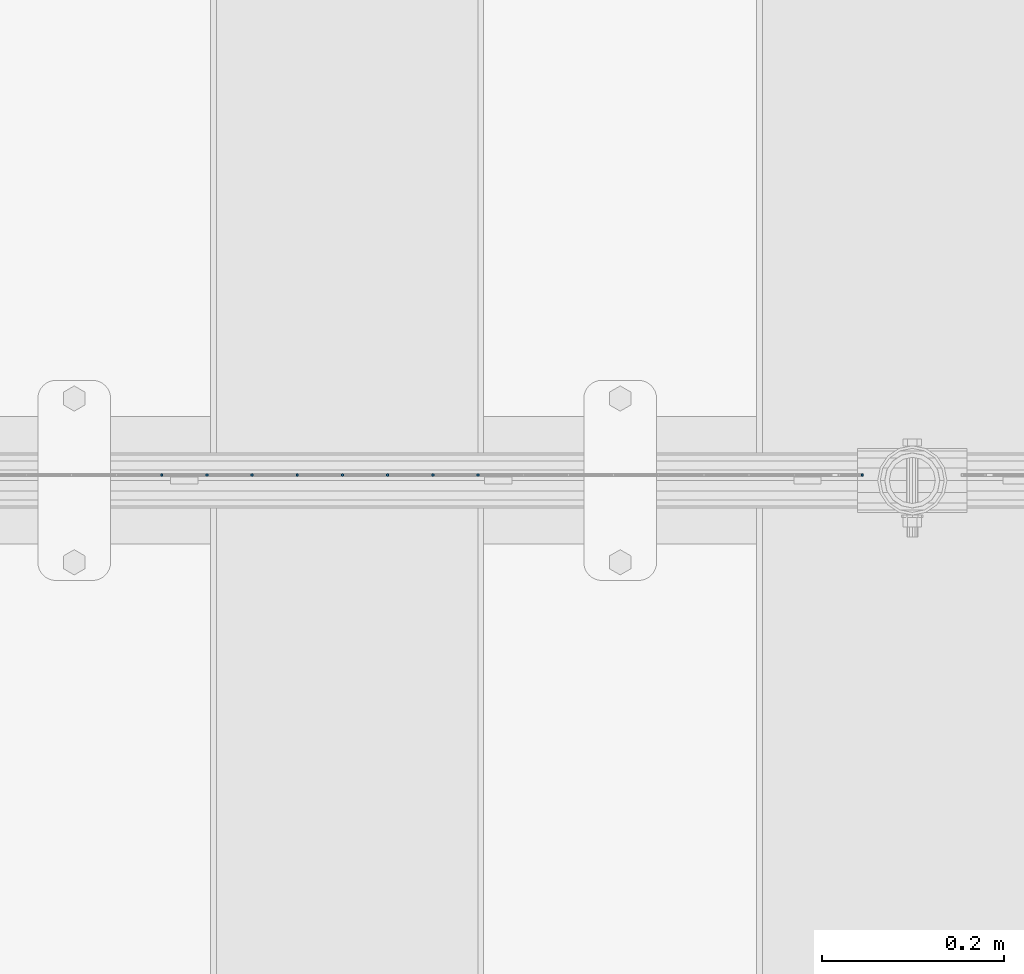
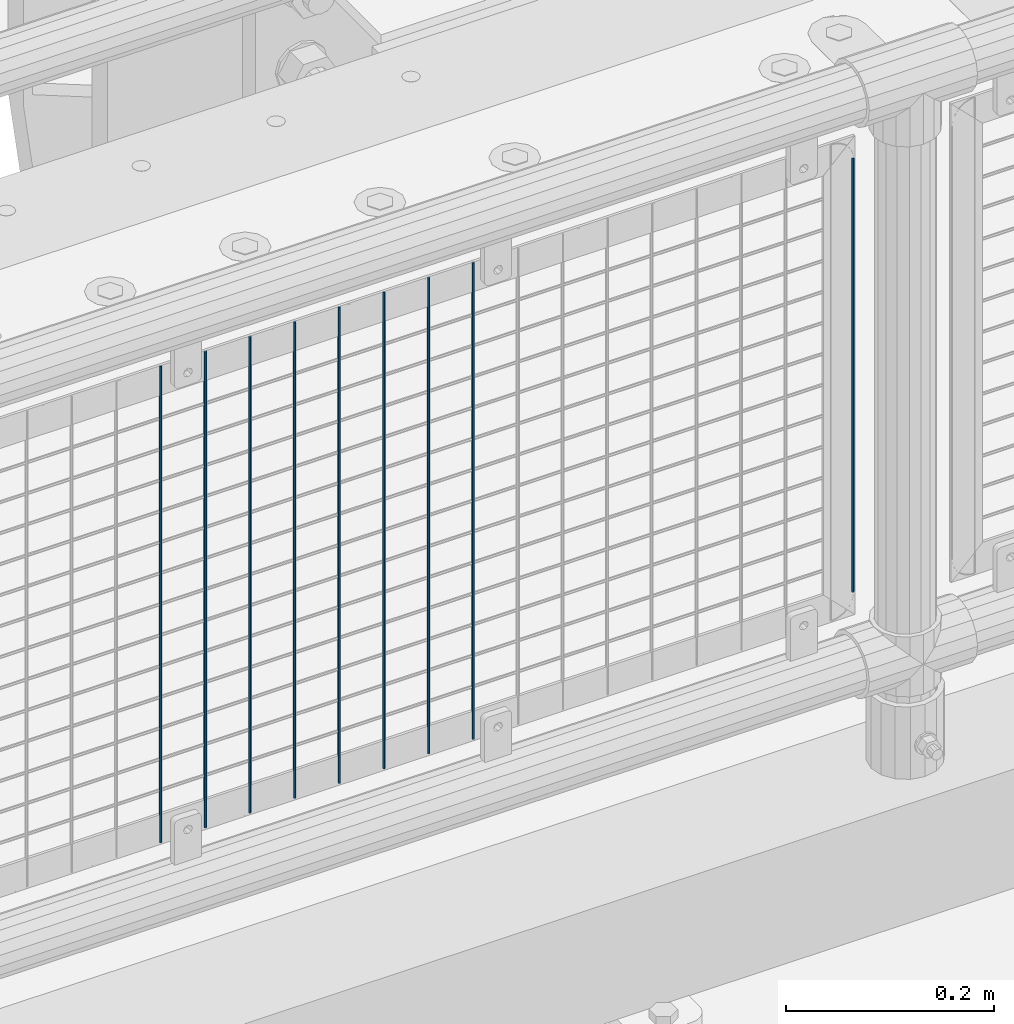
# One storey, part 78 of 208: 9 columns.
"""IFC2X3 building model written with IfcOpenShell, lengths in millimetres."""

import ifcopenshell
import ifcopenshell.guid

model = None  # the IFC model being written
_history = None  # IfcOwnerHistory: only IFC2X3 demands one
_inside = {}  # id of a spatial element -> (the spatial element, [elements in it])
_under = {}  # id of a project, library or spatial element -> (it, [spatial elements below it])
_declared = {}  # id of a project -> (the project, [libraries it declares])
_typed = {}  # id of a type object -> (the type object, [elements of that type])
_made_of = {}  # id of a material, layer set ... -> (it, [elements and type objects made of it])


def new_model(schema):
    """Start an empty IFC model of exactly this schema.

    Asked for "IFC4X3", IfcOpenShell would pick the latest addendum, in which some entities
    have other attributes; the version numbers below select the first issue.
    IFC2X3 requires an IfcOwnerHistory on every rooted entity: one is made here for all.
    """
    global model, _history
    if schema == "IFC4X3":
        model = ifcopenshell.file(schema_version=(4, 3, 0, 0))
    else:
        model = ifcopenshell.file(schema=schema)
    _inside.clear()
    _under.clear()
    _declared.clear()
    _typed.clear()
    _made_of.clear()
    _history = None
    if model.schema == "IFC2X3":
        org = make("IfcOrganization", Name="unknown")
        user = make(
            "IfcPersonAndOrganization",
            ThePerson=make("IfcPerson", FamilyName="unknown"),
            TheOrganization=org,
        )
        app = make(
            "IfcApplication",
            ApplicationDeveloper=org,
            Version="unknown",
            ApplicationFullName="unknown",
            ApplicationIdentifier="unknown",
        )
        _history = make(
            "IfcOwnerHistory",
            OwningUser=user,
            OwningApplication=app,
            ChangeAction="ADDED",
            CreationDate=0,
        )
    return model


def make(cls, **values):
    """One entity of the class cls with the attributes given. An attribute that is None is left unset."""
    return model.create_entity(
        cls, **{name: value for name, value in values.items() if value is not None}
    )


def rooted(cls, **values):
    """An entity with a GlobalId (a new one), such as an element, a storey or a relation."""
    return make(cls, GlobalId=ifcopenshell.guid.new(), OwnerHistory=_history, **values)


def si_unit(unit_type, name, prefix=None):
    """IfcSIUnit, for example si_unit("LENGTHUNIT", "METRE", prefix="MILLI")."""
    return make("IfcSIUnit", UnitType=unit_type, Prefix=prefix, Name=name)


def assignment(units):
    """IfcUnitAssignment: the units of a project."""
    return None if units is None else make("IfcUnitAssignment", Units=units)


def point(xyz):
    """IfcCartesianPoint."""
    return None if xyz is None else make("IfcCartesianPoint", Coordinates=xyz)


def direction(xyz):
    """IfcDirection."""
    return None if xyz is None else make("IfcDirection", DirectionRatios=xyz)


def frame(location, z_axis=None, x_axis=None):
    """IfcAxis2Placement3D, a coordinate frame: its origin and axes. An axis left out is left unset."""
    return make(
        "IfcAxis2Placement3D",
        Location=point(location),
        Axis=direction(z_axis),
        RefDirection=direction(x_axis),
    )


def origin_with_axes():
    """The frame at (0, 0, 0) with the z axis (0, 0, 1) and the x axis (1, 0, 0) written out."""
    return frame((0.0, 0.0, 0.0), z_axis=(0.0, 0.0, 1.0), x_axis=(1.0, 0.0, 0.0))


def place(relative_to, where):
    """IfcLocalPlacement: puts the frame where relative to a parent placement (None: the world)."""
    return make(
        "IfcLocalPlacement", PlacementRelTo=relative_to, RelativePlacement=where
    )


def context(
    kind, dimensions, precision=None, world=None, true_north=None, identifier=None
):
    """IfcGeometricRepresentationContext, for example the 3D "Model" context."""
    return make(
        "IfcGeometricRepresentationContext",
        ContextIdentifier=identifier,
        ContextType=kind,
        CoordinateSpaceDimension=dimensions,
        Precision=precision,
        WorldCoordinateSystem=world,
        TrueNorth=true_north,
    )


def subcontext(parent, identifier, kind, view, scale=None):
    """IfcGeometricRepresentationSubContext, for example "Body" below "Model"."""
    return make(
        "IfcGeometricRepresentationSubContext",
        ContextIdentifier=identifier,
        ContextType=kind,
        ParentContext=parent,
        TargetScale=scale,
        TargetView=view,
    )


def project(units=None, contexts=None):
    """IfcProject with its units and contexts."""
    return rooted(
        "IfcProject",
        Name="project",
        RepresentationContexts=contexts,
        UnitsInContext=assignment(units),
    )


def spatial(cls, under=None, at=None, **own):
    """A site, building, storey or space (cls), placed at a placement, below another one or the project."""
    s = rooted(cls, ObjectPlacement=at, **own)
    if under is not None:
        _under.setdefault(under.id(), (under, []))[1].append(s)
    return s


def faces_of(points, faces, orient=None, outer=None):
    """IfcFace entities. A face is a list of loops; a loop is a list of indices into points, from 0.

    orient and outer hold one flag for each loop. By default every Orientation is true, the
    first loop of a face is its IfcFaceOuterBound and the others are IfcFaceBound.
    """
    made = []
    for i, loops in enumerate(faces):
        bounds = []
        for j, loop in enumerate(loops):
            is_outer = j == 0 if outer is None else outer[i][j]
            bounds.append(
                make(
                    "IfcFaceOuterBound" if is_outer else "IfcFaceBound",
                    Bound=make("IfcPolyLoop", Polygon=[points[k] for k in loop]),
                    Orientation=True if orient is None else orient[i][j],
                )
            )
        made.append(make("IfcFace", Bounds=bounds))
    return made


def faceted_brep(points, faces, orient=None, outer=None, voids=None):
    """IfcFacetedBrep: a solid bounded by flat faces; with voids (closed shells), ...WithVoids."""
    shared = [point(p) for p in points]
    hull = make("IfcClosedShell", CfsFaces=faces_of(shared, faces, orient, outer))
    if voids is None:
        return make("IfcFacetedBrep", Outer=hull)
    return make(
        "IfcFacetedBrepWithVoids",
        Outer=hull,
        Voids=[
            make(cls, CfsFaces=faces_of(shared, fs, o, b)) for cls, fs, o, b in voids
        ],
    )


def shape(context_of_items, identifier, shape_type, items):
    """IfcShapeRepresentation: the items that make up one representation, for example the "Body"."""
    return make(
        "IfcShapeRepresentation",
        ContextOfItems=context_of_items,
        RepresentationIdentifier=identifier,
        RepresentationType=shape_type,
        Items=items,
    )


def material(Name=None, Category=None):
    """IfcMaterial."""
    return make("IfcMaterial", Name=Name, Category=Category)


def made_of(thing, what):
    """Note that an element or type object is made of a material, layer set ...; save() writes the relation."""
    if what is not None:
        _made_of.setdefault(what.id(), (what, []))[1].append(thing)
    return thing


def type_object(cls, material=None, **own):
    """A type object (cls), such as IfcWallType, which elements share."""
    return made_of(rooted(cls, **own), material)


def element(
    cls,
    number,
    at=None,
    inside=None,
    cuts=None,
    type_object=None,
    material=None,
    context=None,
    identifier="Body",
    shape_type=None,
    held_by="IfcProductDefinitionShape",
    body=None,
    shapes=None,
    **own,
):
    """One element of the class cls, such as IfcWall. Its Tag is "e" and its number.

    at: its placement. inside: the storey or other place that contains it. cuts: it is an
    opening in that element (IfcRelVoidsElement). A single representation is given by context,
    identifier, shape_type and body (its items); several are given by shapes. held_by: the class
    of the entity that holds the representations. save() writes the other relations.
    """
    e = rooted(cls, Tag="e%d" % number, ObjectPlacement=at, **own)
    if body is not None:
        shapes = [shape(context, identifier, shape_type, body)]
    if shapes is not None:
        e.Representation = make(held_by, Representations=shapes)
    if inside is not None:
        _inside.setdefault(inside.id(), (inside, []))[1].append(e)
    if cuts is not None:
        rooted(
            "IfcRelVoidsElement", RelatingBuildingElement=cuts, RelatedOpeningElement=e
        )
    if type_object is not None:
        _typed.setdefault(type_object.id(), (type_object, []))[1].append(e)
    return made_of(e, material)


def aggregate(whole, parts):
    """IfcRelAggregates: a whole, such as a stair, and the parts it consists of."""
    return rooted("IfcRelAggregates", RelatingObject=whole, RelatedObjects=parts)


def save(model, path):
    """Write the relations noted so far, then the file.

    IfcRelAggregates (storeys below a building ...), IfcRelContainedInSpatialStructure (elements
    in a storey), IfcRelDefinesByType, IfcRelAssociatesMaterial and IfcRelDeclares: one each for
    every whole, place, type object, material and project.
    """
    for whole, parts in _under.values():
        aggregate(whole, parts)
    for where, things in _inside.values():
        rooted(
            "IfcRelContainedInSpatialStructure",
            RelatedElements=things,
            RelatingStructure=where,
        )
    for kind, things in _typed.values():
        rooted("IfcRelDefinesByType", RelatedObjects=things, RelatingType=kind)
    for what, things in _made_of.values():
        rooted("IfcRelAssociatesMaterial", RelatedObjects=things, RelatingMaterial=what)
    for by, libraries in _declared.values():
        rooted("IfcRelDeclares", RelatingContext=by, RelatedDefinitions=libraries)
    model.write(path)


model = new_model("IFC2X3")

# Units and contexts
model_context = context("Model", 3, precision=1e-05, world=origin_with_axes())
body_context = subcontext(model_context, "Body", "Model", "MODEL_VIEW")
ifc_project = project(units=[si_unit("LENGTHUNIT", "METRE", prefix="MILLI"), si_unit("AREAUNIT", "SQUARE_METRE"), si_unit("VOLUMEUNIT", "CUBIC_METRE"), si_unit("MASSUNIT", "GRAM", prefix="KILO"), si_unit("TIMEUNIT", "SECOND"), si_unit("PLANEANGLEUNIT", "RADIAN"), si_unit("SOLIDANGLEUNIT", "STERADIAN"), si_unit("THERMODYNAMICTEMPERATUREUNIT", "DEGREE_CELSIUS"), si_unit("LUMINOUSINTENSITYUNIT", "LUMEN")], contexts=[model_context])

# Site, building, storey
site_placement = place(None, origin_with_axes())
site = spatial("IfcSite", under=ifc_project, at=site_placement, CompositionType="ELEMENT")
building_placement = place(site_placement, origin_with_axes())
building = spatial("IfcBuilding", under=site, at=building_placement, Name="Standard", CompositionType="ELEMENT")
storey_placement = place(building_placement, origin_with_axes())
storey = spatial("IfcBuildingStorey", under=building, at=storey_placement, Name="Undefined", CompositionType="ELEMENT", Elevation=0.0)

# Columns
ifc_material = material(Name="Misc_Undefined")
column_type = type_object("IfcColumnType", Name="D3", PredefinedType="NOTDEFINED")
for number, where, z_axis, x_axis in (
    (1, (-31106.245, 4670.50000000001, 353.020000000004), (-1.0, 0.0, 0.0), (0.0, 0.0, 1.0)),
    (2, (-31155.9, 4670.50000000001, 353.020000000004), (-1.0, 0.0, 0.0), (0.0, 0.0, 1.0)),
    (3, (-31205.555, 4670.50000000001, 353.020000000004), (-1.0, 0.0, 0.0), (0.0, 0.0, 1.0)),
    (4, (-31255.21, 4670.50000000001, 353.020000000004), (-1.0, 0.0, 0.0), (0.0, 0.0, 1.0)),
    (5, (-31304.865, 4670.50000000001, 353.020000000004), (-1.0, 0.0, 0.0), (0.0, 0.0, 1.0)),
    (6, (-31354.52, 4670.50000000001, 353.020000000004), (-1.0, 0.0, 0.0), (0.0, 0.0, 1.0)),
    (7, (-31404.175, 4670.50000000001, 353.020000000004), (-1.0, 0.0, 0.0), (0.0, 0.0, 1.0)),
    (8, (-31453.83, 4670.50000000001, 353.020000000004), (-1.0, 0.0, 0.0), (0.0, 0.0, 1.0)),
):
    element("IfcColumn", number, at=place(storey_placement, frame(where, z_axis=z_axis, x_axis=x_axis)), inside=storey, type_object=column_type, material=ifc_material, ObjectType="D3", context=body_context, shape_type="Brep", body=[
        faceted_brep([(0.0, -1.49999999999909, 3.63797880709171e-12), (-7.27595761418343e-12, -0.749999999999091, -1.29903810567669), (560.0, -0.75, -1.29903810567703), (560.0, -1.5, 0.0), (-3.63797880709171e-12, 0.750000000000909, -1.29903810567669), (560.0, 0.75, -1.29903810567703), (0.0, 1.50000000000182, 3.63797880709171e-12), (560.0, 1.5, 0.0), (-3.63797880709171e-12, 0.750000000000909, 1.29903810567669), (560.0, 0.75, 1.29903810567703), (-7.27595761418343e-12, -0.749999999999091, 1.29903810567669), (560.0, -0.75, 1.29903810567703)], [[[0, 1, 2, 3]], [[1, 4, 5, 2]], [[4, 6, 7, 5]], [[6, 8, 9, 7]], [[8, 10, 11, 9]], [[10, 0, 3, 11]], [[5, 7, 9, 11, 3, 2]], [[10, 8, 6, 4, 1, 0]]]),
    ])
column_placement = place(storey_placement, frame((-30684.0, 4670.5, 378.020000000004), z_axis=(-1.0, 0.0, 0.0), x_axis=(0.0, 0.0, 1.0)))
element("IfcColumn", 9, at=column_placement, inside=storey, type_object=column_type, material=ifc_material, ObjectType="D3", context=body_context, shape_type="Brep", body=[
    faceted_brep([(0.0, -1.49999999999909, 3.63797880709171e-12), (-7.27595761418343e-12, -0.749999999999091, -1.29903810567669), (510.0, -0.75, -1.29903810567703), (510.0, -1.5, 0.0), (-3.63797880709171e-12, 0.750000000000909, -1.29903810567669), (510.0, 0.75, -1.29903810567703), (0.0, 1.50000000000182, 3.63797880709171e-12), (510.0, 1.5, 0.0), (-3.63797880709171e-12, 0.750000000000909, 1.29903810567669), (510.0, 0.75, 1.29903810567703), (-7.27595761418343e-12, -0.749999999999091, 1.29903810567669), (510.0, -0.75, 1.29903810567703)], [[[0, 1, 2, 3]], [[1, 4, 5, 2]], [[4, 6, 7, 5]], [[6, 8, 9, 7]], [[8, 10, 11, 9]], [[10, 0, 3, 11]], [[5, 7, 9, 11, 3, 2]], [[10, 8, 6, 4, 1, 0]]]),
])

save(model, "model.ifc")
